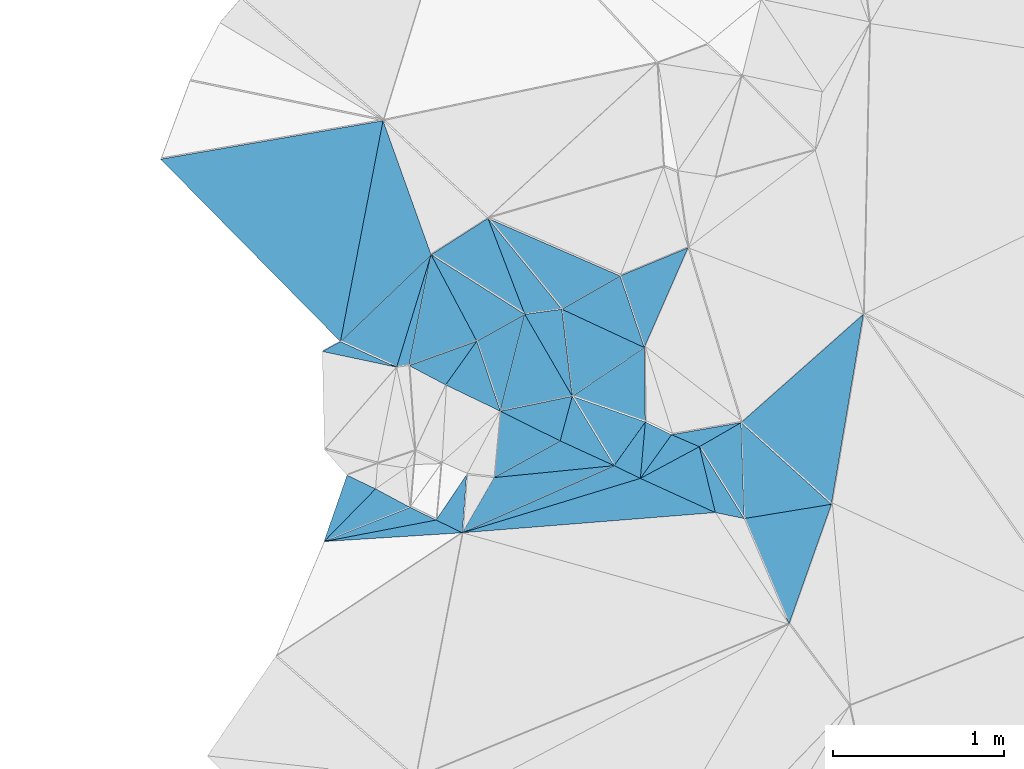
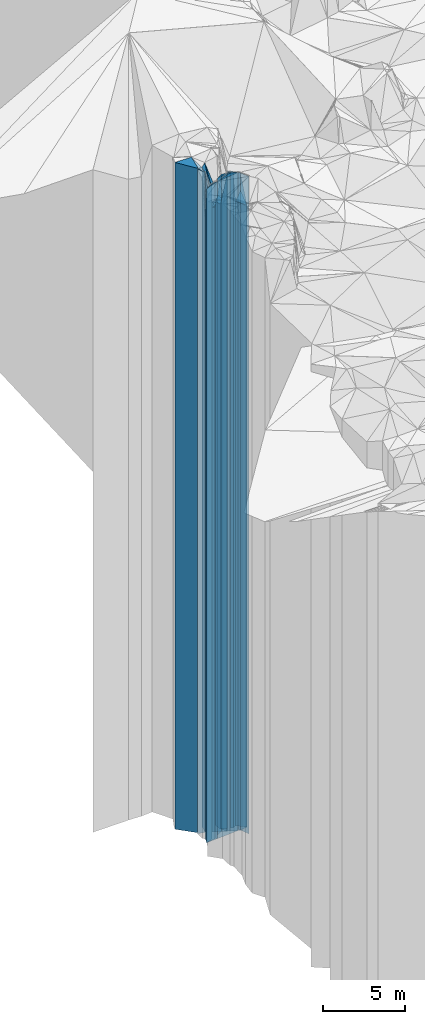
# One storey, part 237 of 275: 42 plates.
"""IFC2X3 building model written with IfcOpenShell, lengths in millimetres."""

from ifc_helpers import new_model, si_unit, frame, origin_with_axes, place, context, subcontext, project, spatial, faceted_brep, material, type_object, element, save


model = new_model("IFC2X3")

# Units and contexts
model_context = context("Model", 3, precision=1e-05, world=origin_with_axes())
body_context = subcontext(model_context, "Body", "Model", "MODEL_VIEW")
ifc_project = project(units=[si_unit("LENGTHUNIT", "METRE", prefix="MILLI"), si_unit("AREAUNIT", "SQUARE_METRE"), si_unit("VOLUMEUNIT", "CUBIC_METRE"), si_unit("MASSUNIT", "GRAM", prefix="KILO"), si_unit("TIMEUNIT", "SECOND"), si_unit("PLANEANGLEUNIT", "RADIAN"), si_unit("SOLIDANGLEUNIT", "STERADIAN"), si_unit("THERMODYNAMICTEMPERATUREUNIT", "DEGREE_CELSIUS"), si_unit("LUMINOUSINTENSITYUNIT", "LUMEN")], contexts=[model_context])

# Site, building, storey
site_placement = place(None, origin_with_axes())
site = spatial("IfcSite", under=ifc_project, at=site_placement, CompositionType="ELEMENT")
building_placement = place(site_placement, origin_with_axes())
building = spatial("IfcBuilding", under=site, at=building_placement, Name="Undefined", CompositionType="ELEMENT")
storey_placement = place(building_placement, origin_with_axes())
storey = spatial("IfcBuildingStorey", under=building, at=storey_placement, Name="Undefined", CompositionType="ELEMENT", Elevation=0.0)

# Plates
ifc_material = material()
plate_type_1 = type_object("IfcPlateType", PredefinedType="NOTDEFINED")
plate_1_placement = place(storey_placement, frame((-136041.558741659, 92091.3909936193, 32264.0), z_axis=(0.971640857863076, 0.236461504966677, 0.0), x_axis=(0.236461504966685, -0.971640857863074, 0.0)))
element("IfcPlate", 1, at=plate_1_placement, inside=storey, type_object=plate_type_1, material=ifc_material, Name="00", context=body_context, shape_type="Brep", body=[
    faceted_brep([(-2.91038304567337e-11, -24436.0, -1.45519152283669e-11), (469.926422119141, -24526.0, 155.464370727539), (469.926422119141, 24436.0, 155.464370727539), (0.0, 24436.0, 0.0), (396.232269287109, -24586.0, 2.66300048679113e-09), (396.232269287109, 24436.0, 2.66300048679113e-09)], [[[0, 1, 2, 3]], [[1, 4, 5, 2]], [[4, 0, 3, 5]], [[5, 3, 2]], [[4, 1, 0]]]),
])
plate_type_2 = type_object("IfcPlateType", PredefinedType="NOTDEFINED")
plate_2_placement = place(storey_placement, frame((-135779.383697276, 91671.5526365072, 31079.0), z_axis=(-0.999471889003235, -0.0324952780001071, 0.0), x_axis=(-0.0324952780001202, 0.999471889003235, 0.0)))
element("IfcPlate", 2, at=plate_2_placement, inside=storey, type_object=plate_type_2, material=ifc_material, Name="00", context=body_context, shape_type="Brep", body=[
    faceted_brep([(0.0, -25711.0, 2.91038304567337e-11), (428.136077880859, -25621.0, 248.393829345732), (428.136077880859, 23251.0, 248.393829345732), (0.0, 23251.0, 2.91038304567337e-11), (560.802978515625, -23251.0, -5.82076609134674e-10), (560.802978515625, 23251.0, -5.82076609134674e-10)], [[[0, 1, 2, 3]], [[1, 4, 5, 2]], [[4, 0, 3, 5]], [[5, 3, 2]], [[4, 1, 0]]]),
])
plate_type_3 = type_object("IfcPlateType", PredefinedType="NOTDEFINED")
plate_3_placement = place(storey_placement, frame((-135947.865066288, 91706.3955453406, 32264.0), z_axis=(-0.971640857863076, -0.236461504966677, 0.0), x_axis=(-0.236461504966676, 0.971640857863076, 0.0)))
element("IfcPlate", 3, at=plate_3_placement, inside=storey, type_object=plate_type_3, material=ifc_material, Name="00", context=body_context, shape_type="Brep", body=[
    faceted_brep([(1.45519152283669e-11, -24586.0, 1.45519152283669e-11), (297.805145263686, -24576.0, 378.565856933623), (297.805145263686, 24436.0, 378.565856933623), (0.0, 24436.0, 0.0), (396.232269287124, -24436.0, 2.6775524020195e-09), (396.232269287109, 24436.0, 2.66300048679113e-09)], [[[0, 1, 2, 3]], [[1, 4, 5, 2]], [[4, 0, 3, 5]], [[5, 3, 2]], [[4, 1, 0]]]),
])
plate_type_4 = type_object("IfcPlateType", PredefinedType="NOTDEFINED")
plate_4_placement = place(storey_placement, frame((-137609.148746292, 93213.2918704249, 32359.0), z_axis=(0.956207195936515, -0.292690618980567, 0.0), x_axis=(-0.292690618980582, -0.95620719593651, 0.0)))
element("IfcPlate", 4, at=plate_4_placement, inside=storey, type_object=plate_type_4, material=ifc_material, Name="00", context=body_context, shape_type="Brep", body=[
    faceted_brep([(0.0, -24531.0, -2.91038304567337e-11), (656.994262695305, -24601.0, 66.0193405151076), (656.994262695305, 24531.0, 66.0193405151076), (0.0, 24531.0, -2.91038304567337e-11), (687.67724609375, -24631.0, -2.03726813197136e-09), (687.67724609375, 24531.0, -2.03726813197136e-09)], [[[0, 1, 2, 3]], [[1, 4, 5, 2]], [[4, 0, 3, 5]], [[5, 3, 2]], [[4, 1, 0]]]),
])
plate_type_5 = type_object("IfcPlateType", PredefinedType="NOTDEFINED")
plate_5_placement = place(storey_placement, frame((-136357.056062541, 92236.1716570943, 31079.0), z_axis=(-0.999895629829874, -0.0144474719975415, 0.0), x_axis=(-0.0144474719975515, 0.999895629829874, 0.0)))
element("IfcPlate", 5, at=plate_5_placement, inside=storey, type_object=plate_type_5, material=ifc_material, Name="00", context=body_context, shape_type="Brep", body=[
    faceted_brep([(0.0, -25651.0, -2.91038304567337e-11), (156.226181030288, -23251.0, 424.962799072295), (156.226181030288, 23251.0, 424.962799072295), (0.0, 23251.0, 2.91038304567337e-11), (434.626281738296, -23271.0, -1.01863406598568e-09), (434.626281738296, 23251.0, -1.01863406598568e-09)], [[[0, 1, 2, 3]], [[1, 4, 5, 2]], [[4, 0, 3, 5]], [[5, 3, 2]], [[4, 1, 0]]]),
])
plate_type_6 = type_object("IfcPlateType", PredefinedType="NOTDEFINED")
plate_6_placement = place(storey_placement, frame((-136784.231584022, 92386.2418868125, 31079.0), z_axis=(-0.560021342031203, 0.82847818104617, 0.0), x_axis=(0.828478181046171, 0.560021342031202, 0.0)))
element("IfcPlate", 6, at=plate_6_placement, inside=storey, type_object=plate_type_6, material=ifc_material, Name="00", context=body_context, shape_type="Brep", body=[
    faceted_brep([(7.27595761418343e-12, -23251.0, 2.91038304567337e-11), (234.432464599631, -23301.0, 455.676879882842), (234.432464599631, 23251.0, 455.676879882842), (0.0, 23251.0, 2.91038304567337e-11), (508.035430908203, -23271.0, -1.54250301420689e-09), (508.035430908203, 23251.0, -1.54250301420689e-09)], [[[0, 1, 2, 3]], [[1, 4, 5, 2]], [[4, 0, 3, 5]], [[5, 3, 2]], [[4, 1, 0]]]),
])
plate_type_7 = type_object("IfcPlateType", PredefinedType="NOTDEFINED")
plate_7_placement = place(storey_placement, frame((-136203.880321449, 92161.7593439945, 31079.0), z_axis=(0.397745432997045, 0.917495814993176, 0.0), x_axis=(0.917495814993178, -0.397745432997043, 0.0)))
element("IfcPlate", 7, at=plate_7_placement, inside=storey, type_object=plate_type_7, material=ifc_material, Name="00", context=body_context, shape_type="Brep", body=[
    faceted_brep([(0.0, -25651.0, -2.91038304567337e-11), (344.792388915987, -23251.0, 226.093368530255), (344.792388915987, 23251.0, 226.093368530255), (0.0, 23251.0, 2.91038304567337e-11), (176.918060302705, -25621.0, 1.37879396788776e-09), (176.918060302705, 23251.0, 1.37879396788776e-09)], [[[0, 1, 2, 3]], [[1, 4, 5, 2]], [[4, 0, 3, 5]], [[5, 3, 2]], [[4, 1, 0]]]),
])
plate_type_8 = type_object("IfcPlateType", PredefinedType="NOTDEFINED")
plate_8_placement = place(storey_placement, frame((-135779.383697276, 91671.5526365072, 30984.0), z_axis=(-0.161243552034099, 0.986914645208706, 0.0), x_axis=(0.986914645208708, 0.161243552034091, 0.0)))
element("IfcPlate", 8, at=plate_8_placement, inside=storey, type_object=plate_type_8, material=ifc_material, Name="00", context=body_context, shape_type="Brep", body=[
    faceted_brep([(0.0, -25806.0, 1.45519152283669e-11), (72.3931198119972, -23346.0, 556.110839843765), (72.3931198119972, 23156.0, 556.110839843765), (-7.27595761418343e-12, 23156.0, 0.0), (516.623657226548, -23156.0, 1.00408215075731e-09), (516.623657226548, 23156.0, 1.00408215075731e-09)], [[[0, 1, 2, 3]], [[1, 4, 5, 2]], [[4, 0, 3, 5]], [[5, 3, 2]], [[4, 1, 0]]]),
])
plate_type_9 = type_object("IfcPlateType", PredefinedType="NOTDEFINED")
plate_9_placement = place(storey_placement, frame((-137609.148746292, 93213.2918704249, 31104.0), z_axis=(0.88403111089803, 0.467428063946096, 0.0), x_axis=(0.467428063946066, -0.884031110898046, 0.0)))
element("IfcPlate", 9, at=plate_9_placement, inside=storey, type_object=plate_type_9, material=ifc_material, Name="00", context=body_context, shape_type="Brep", body=[
    faceted_brep([(0.0, -25786.0, 0.0), (563.876403808594, -23296.0, 321.315063476577), (563.876403808594, 23276.0, 321.315063476577), (0.0, 23276.0, 0.0), (571.401794433594, -23276.0, 1.30967237055302e-10), (571.401794433594, 23276.0, 1.30967237055302e-10)], [[[0, 1, 2, 3]], [[1, 4, 5, 2]], [[4, 0, 3, 5]], [[5, 3, 2]], [[4, 1, 0]]]),
])
plate_type_10 = type_object("IfcPlateType", PredefinedType="NOTDEFINED")
plate_10_placement = place(storey_placement, frame((-136784.231584022, 92386.2418868125, 31079.0), z_axis=(-0.992897616102511, -0.118971946012288, 0.0), x_axis=(-0.118971946012274, 0.992897616102513, 0.0)))
element("IfcPlate", 10, at=plate_10_placement, inside=storey, type_object=plate_type_10, material=ifc_material, Name="00", context=body_context, shape_type="Brep", body=[
    faceted_brep([(7.27595761418343e-12, -23251.0, 2.91038304567337e-11), (508.347106933608, -23321.0, 218.364852905288), (508.347106933608, 23251.0, 218.364852905288), (0.0, 23251.0, 2.91038304567337e-11), (512.445129394531, -23301.0, 3.79804987460375e-09), (512.445129394531, 23251.0, 3.79804987460375e-09)], [[[0, 1, 2, 3]], [[1, 4, 5, 2]], [[4, 0, 3, 5]], [[5, 3, 2]], [[4, 1, 0]]]),
])
plate_type_11 = type_object("IfcPlateType", PredefinedType="NOTDEFINED")
plate_11_placement = place(storey_placement, frame((-136504.686318748, 93089.3453249089, 31089.0), z_axis=(0.947440181025233, 0.319932967008517, 0.0), x_axis=(0.319932967008536, -0.947440181025227, 0.0)))
element("IfcPlate", 11, at=plate_11_placement, inside=storey, type_object=plate_type_11, material=ifc_material, Name="00", context=body_context, shape_type="Brep", body=[
    faceted_brep([(0.0, -23411.0, 0.0), (-28.9714393616014, -23391.0, 429.139434814424), (-28.9714393616014, 23261.0, 429.139434814424), (0.0, 23261.0, 0.0), (441.814453125, -23261.0, 1.89174897968769e-09), (441.814453125, 23261.0, 1.89174897968769e-09)], [[[0, 1, 2, 3]], [[1, 4, 5, 2]], [[4, 0, 3, 5]], [[5, 3, 2]], [[4, 1, 0]]]),
])
plate_type_12 = type_object("IfcPlateType", PredefinedType="NOTDEFINED")
plate_12_placement = place(storey_placement, frame((-138139.112548315, 92705.6124749946, 32359.0), z_axis=(-0.691761460959168, 0.722126083957392, 0.0), x_axis=(0.722126083957394, 0.691761460959166, 0.0)))
element("IfcPlate", 12, at=plate_12_placement, inside=storey, type_object=plate_type_12, material=ifc_material, Name="00", context=body_context, shape_type="Brep", body=[
    faceted_brep([(-1.45519152283669e-11, -24941.0, 0.0), (1073.04370117188, -24921.0, 759.919311523438), (1073.04370117188, 24531.0, 759.919311523438), (0.0, 24531.0, -2.91038304567337e-11), (733.893737792969, -24531.0, -2.00816430151463e-09), (733.893737792969, 24531.0, -2.00816430151463e-09)], [[[0, 1, 2, 3]], [[1, 4, 5, 2]], [[4, 0, 3, 5]], [[5, 3, 2]], [[4, 1, 0]]]),
])
plate_type_13 = type_object("IfcPlateType", PredefinedType="NOTDEFINED")
plate_13_placement = place(storey_placement, frame((-136845.198177058, 92895.0474238634, 31104.0), z_axis=(-0.495599859991453, 0.868550964985045, 0.0), x_axis=(0.868550964985053, 0.495599859991438, 0.0)))
element("IfcPlate", 13, at=plate_13_placement, inside=storey, type_object=plate_type_13, material=ifc_material, Name="00", context=body_context, shape_type="Brep", body=[
    faceted_brep([(1.45519152283669e-11, -23276.0, 0.0), (-111.721611022935, -25906.0, 674.920959472656), (-111.721611022935, 23276.0, 674.920959472656), (0.0, 23276.0, 0.0), (392.045928955093, -23396.0, -2.3283064365387e-09), (392.045928955093, 23276.0, -2.3283064365387e-09)], [[[0, 1, 2, 3]], [[1, 4, 5, 2]], [[4, 0, 3, 5]], [[5, 3, 2]], [[4, 1, 0]]]),
])
plate_type_14 = type_object("IfcPlateType", PredefinedType="NOTDEFINED")
plate_14_placement = place(storey_placement, frame((-136504.686318748, 93089.3453249089, 31089.0), z_axis=(0.495599859991453, -0.868550964985045, 0.0), x_axis=(-0.868550964985035, -0.49559985999147, 0.0)))
element("IfcPlate", 14, at=plate_14_placement, inside=storey, type_object=plate_type_14, material=ifc_material, Name="00", context=body_context, shape_type="Brep", body=[
    faceted_brep([(0.0, -23411.0, 0.0), (84.6839599609229, -23261.0, 433.622680664063), (84.6839599609229, 23261.0, 433.622680664063), (0.0, 23261.0, 0.0), (392.045928955078, -23291.0, -2.3283064365387e-09), (392.045928955078, 23261.0, -2.3283064365387e-09)], [[[0, 1, 2, 3]], [[1, 4, 5, 2]], [[4, 0, 3, 5]], [[5, 3, 2]], [[4, 1, 0]]]),
])
plate_type_15 = type_object("IfcPlateType", PredefinedType="NOTDEFINED")
plate_15_placement = place(storey_placement, frame((-137061.524566055, 92864.9992388348, 31104.0), z_axis=(-0.137581187998973, 0.990490492992634, 0.0), x_axis=(0.990490492992633, 0.137581187998979, 0.0)))
element("IfcPlate", 15, at=plate_15_placement, inside=storey, type_object=plate_type_15, material=ifc_material, Name="00", context=body_context, shape_type="Brep", body=[
    faceted_brep([(0.0, -23296.0, 0.0), (-135.986953735366, -25906.0, 585.156005859375), (-135.986953735366, 23276.0, 585.156005859375), (0.0, 23276.0, 0.0), (218.403289794922, -23276.0, -9.16770659387112e-10), (218.403289794922, 23276.0, -9.16770659387112e-10)], [[[0, 1, 2, 3]], [[1, 4, 5, 2]], [[4, 0, 3, 5]], [[5, 3, 2]], [[4, 1, 0]]]),
])
plate_type_16 = type_object("IfcPlateType", PredefinedType="NOTDEFINED")
plate_16_placement = place(storey_placement, frame((-137738.316629679, 92565.7459972227, 31104.0), z_axis=(-0.338207177069304, 0.94107167919283, 0.0), x_axis=(0.941071679192833, 0.338207177069296, 0.0)))
element("IfcPlate", 16, at=plate_16_placement, inside=storey, type_object=plate_type_16, material=ifc_material, Name="00", context=body_context, shape_type="Brep", body=[
    faceted_brep([(0.0, -25856.0, 0.0), (340.560913085938, -25786.0, 565.701599121094), (340.560913085938, 23276.0, 565.701599121094), (0.0, 23276.0, 0.0), (421.070068359404, -23276.0, 2.88127921521664e-09), (421.070068359404, 23276.0, 2.88127921521664e-09)], [[[0, 1, 2, 3]], [[1, 4, 5, 2]], [[4, 0, 3, 5]], [[5, 3, 2]], [[4, 1, 0]]]),
])
plate_type_17 = type_object("IfcPlateType", PredefinedType="NOTDEFINED")
plate_17_placement = place(storey_placement, frame((-139189.996780718, 93771.6998682641, 32554.0), z_axis=(0.712166546939761, 0.702010547940625, 0.0), x_axis=(0.702010547940622, -0.712166546939764, 0.0)))
element("IfcPlate", 17, at=plate_17_placement, inside=storey, type_object=plate_type_17, material=ifc_material, Name="00", context=body_context, shape_type="Brep", body=[
    faceted_brep([(0.0, -24926.0, 7.27595761418343e-12), (752.456481933594, -24726.0, 1083.79394531251), (752.456481933594, 24726.0, 1083.79394531251), (2.91038304567337e-11, 24726.0, 0.0), (1496.96362304688, -24746.0, -3.71073838323355e-10), (1496.96362304688, 24726.0, -3.71073838323355e-10)], [[[0, 1, 2, 3]], [[1, 4, 5, 2]], [[4, 0, 3, 5]], [[5, 3, 2]], [[4, 1, 0]]]),
])
plate_type_18 = type_object("IfcPlateType", PredefinedType="NOTDEFINED")
plate_18_placement = place(storey_placement, frame((-137061.524566055, 92864.9992388348, 31074.0), z_axis=(0.969472134967555, -0.245201507991795, 0.0), x_axis=(-0.245201507991806, -0.969472134967553, 0.0)))
element("IfcPlate", 18, at=plate_18_placement, inside=storey, type_object=plate_type_18, material=ifc_material, Name="00", context=body_context, shape_type="Brep", body=[
    faceted_brep([(0.0, -23326.0, -7.27595761418343e-12), (396.149261474588, -23256.0, 386.219848632813), (396.149261474588, 23246.0, 386.219848632813), (1.09139364212751e-11, 23246.0, 2.91038304567337e-11), (584.12329101561, -23246.0, -5.82076609134674e-10), (584.12329101561, 23246.0, -5.82076609134674e-10)], [[[0, 1, 2, 3]], [[1, 4, 5, 2]], [[4, 0, 3, 5]], [[5, 3, 2]], [[4, 1, 0]]]),
])
plate_type_19 = type_object("IfcPlateType", PredefinedType="NOTDEFINED")
plate_19_placement = place(storey_placement, frame((-137061.524566055, 92864.9992388348, 31114.0), z_axis=(-0.933637365146917, -0.358219584056374, 0.0), x_axis=(-0.35821958405635, 0.933637365146927, 0.0)))
element("IfcPlate", 19, at=plate_19_placement, inside=storey, type_object=plate_type_19, material=ifc_material, Name="00", context=body_context, shape_type="Brep", body=[
    faceted_brep([(-1.09139364212751e-11, -23286.0, 0.0), (521.348693847685, -25776.0, 386.517150878906), (521.348693847685, 23286.0, 386.517150878906), (0.0, 23286.0, 0.0), (600.74951171875, -25896.0, 3.97267285734415e-09), (600.74951171875, 23286.0, 3.97267285734415e-09)], [[[0, 1, 2, 3]], [[1, 4, 5, 2]], [[4, 0, 3, 5]], [[5, 3, 2]], [[4, 1, 0]]]),
])
plate_type_20 = type_object("IfcPlateType", PredefinedType="NOTDEFINED")
plate_20_placement = place(storey_placement, frame((-136386.114562693, 91906.2389312714, 32279.0), z_axis=(-0.81415573206253, 0.580646574044595, 0.0), x_axis=(0.580646574044601, 0.814155732062526, 0.0)))
element("IfcPlate", 20, at=plate_20_placement, inside=storey, type_object=plate_type_20, material=ifc_material, Name="00", context=body_context, shape_type="Brep", body=[
    faceted_brep([(0.0, -24561.0, 0.0), (285.489349365218, -24451.0, 167.916168212891), (285.489349365218, 24451.0, 167.916168212891), (-1.63709046319127e-11, 24451.0, 0.0), (313.847106933577, -24451.0, 2.44472175836563e-09), (313.847106933577, 24451.0, 2.44472175836563e-09)], [[[0, 1, 2, 3]], [[1, 4, 5, 2]], [[4, 0, 3, 5]], [[5, 3, 2]], [[4, 1, 0]]]),
])
plate_21_placement = place(storey_placement, frame((-136357.056062541, 92236.1716570943, 32279.0), z_axis=(0.814155732062535, -0.580646574044588, 0.0), x_axis=(-0.580646574044615, -0.814155732062516, 0.0)))
element("IfcPlate", 21, at=plate_21_placement, inside=storey, type_object=plate_type_20, material=ifc_material, Name="00", context=body_context, shape_type="Brep", body=[
    faceted_brep([(7.27595761418343e-12, -24451.0, -2.91038304567337e-11), (285.489349365237, -24561.0, 167.916168212891), (285.489349365218, 24451.0, 167.916168212891), (-1.63709046319127e-11, 24451.0, 0.0), (313.847106933582, -24551.0, 2.4156179279089e-09), (313.847106933577, 24451.0, 2.44472175836563e-09)], [[[0, 1, 2, 3]], [[1, 4, 5, 2]], [[4, 0, 3, 5]], [[5, 3, 2]], [[4, 1, 0]]]),
])
plate_type_21 = type_object("IfcPlateType", PredefinedType="NOTDEFINED")
plate_22_placement = place(storey_placement, frame((-137204.752473843, 92298.7080006626, 31074.0), z_axis=(0.443714606160807, 0.896168147324797, 0.0), x_axis=(0.896168147521672, -0.443714605763182, 0.0)))
element("IfcPlate", 22, at=plate_22_placement, inside=storey, type_object=plate_type_21, material=ifc_material, Name="00", context=body_context, shape_type="Brep", body=[
    faceted_brep([(1.09139364212751e-11, -23246.0, 2.91038304567337e-11), (338.017364384315, -23256.0, 265.036346435547), (338.017364384315, 23246.0, 265.036346435547), (1.09139364212751e-11, 23246.0, 2.91038304567337e-11), (390.512481689395, -25716.0, 1.07684172689915e-09), (390.512481689395, 23246.0, 1.07684172689915e-09)], [[[0, 1, 2, 3]], [[1, 4, 5, 2]], [[4, 0, 3, 5]], [[5, 3, 2]], [[4, 1, 0]]]),
])
plate_type_22 = type_object("IfcPlateType", PredefinedType="NOTDEFINED")
plate_23_placement = place(storey_placement, frame((-136386.114562693, 91906.2389312714, 32264.0), z_axis=(-0.473350498214962, 0.880874171400006, 0.0), x_axis=(0.880874171400003, 0.473350498214967, 0.0)))
element("IfcPlate", 23, at=plate_23_placement, inside=storey, type_object=plate_type_22, material=ifc_material, Name="00", context=body_context, shape_type="Brep", body=[
    faceted_brep([(2.91038304567337e-11, -24576.0, 1.45519152283669e-11), (281.47616577147, -24466.0, 138.820663452178), (281.47616577147, 24436.0, 138.820663452178), (0.0, 24436.0, 0.0), (391.152130126953, -24436.0, 3.75439412891865e-09), (391.152130126953, 24436.0, 3.75439412891865e-09)], [[[0, 1, 2, 3]], [[1, 4, 5, 2]], [[4, 0, 3, 5]], [[5, 3, 2]], [[4, 1, 0]]]),
])
plate_type_23 = type_object("IfcPlateType", PredefinedType="NOTDEFINED")
plate_24_placement = place(storey_placement, frame((-136539.290303785, 91980.6512443711, 31079.0), z_axis=(-0.81415573206253, 0.580646574044595, 0.0), x_axis=(0.580646574044601, 0.814155732062526, 0.0)))
element("IfcPlate", 24, at=plate_24_placement, inside=storey, type_object=plate_type_23, material=ifc_material, Name="00", context=body_context, shape_type="Brep", body=[
    faceted_brep([(-1.72803993336856e-11, -25751.0, 0.0), (187.989624023406, -23251.0, 434.925170898438), (187.989624023406, 23251.0, 434.925170898438), (0.0, 23251.0, 2.91038304567337e-11), (313.847106933562, -25651.0, 2.38651409745216e-09), (313.847106933562, 23251.0, 2.38651409745216e-09)], [[[0, 1, 2, 3]], [[1, 4, 5, 2]], [[4, 0, 3, 5]], [[5, 3, 2]], [[4, 1, 0]]]),
])
plate_type_24 = type_object("IfcPlateType", PredefinedType="NOTDEFINED")
plate_25_placement = place(storey_placement, frame((-135779.383697276, 91671.5526365072, 30984.0), z_axis=(0.920517110220634, 0.390702252093654, 0.0), x_axis=(0.390702252093661, -0.920517110220631, 0.0)))
element("IfcPlate", 25, at=plate_25_placement, inside=storey, type_object=plate_type_24, material=ifc_material, Name="00", context=body_context, shape_type="Brep", body=[
    faceted_brep([(0.0, -25806.0, 1.45519152283669e-11), (122.523666381836, -23156.0, 501.884399414048), (122.523666381836, 23156.0, 501.884399414048), (-7.27595761418343e-12, 23156.0, 0.0), (670.074645996094, -25826.0, 5.79166226089001e-09), (670.074645996094, 23156.0, 5.79166226089001e-09)], [[[0, 1, 2, 3]], [[1, 4, 5, 2]], [[4, 0, 3, 5]], [[5, 3, 2]], [[4, 1, 0]]]),
])
plate_type_25 = type_object("IfcPlateType", PredefinedType="NOTDEFINED")
plate_26_placement = place(storey_placement, frame((-135797.607146299, 92232.0594659979, 30984.0), z_axis=(0.670458691751183, 0.741946859724665, 0.0), x_axis=(0.741946859724667, -0.670458691751181, 0.0)))
element("IfcPlate", 26, at=plate_26_placement, inside=storey, type_object=plate_type_25, material=ifc_material, Name="00", context=body_context, shape_type="Brep", body=[
    faceted_brep([(0.0, -23346.0, -1.09139364212751e-11), (105.93482208249, -23546.0, 949.198486328114), (105.93482208249, 23156.0, 949.198486328114), (-7.27595761418343e-12, 23156.0, 0.0), (711.758361816377, -23156.0, 4.77666617371142e-09), (711.758361816377, 23156.0, 4.77666617371142e-09)], [[[0, 1, 2, 3]], [[1, 4, 5, 2]], [[4, 0, 3, 5]], [[5, 3, 2]], [[4, 1, 0]]]),
])
plate_type_26 = type_object("IfcPlateType", PredefinedType="NOTDEFINED")
plate_27_placement = place(storey_placement, frame((-136784.231584022, 92386.2418868125, 31079.0), z_axis=(0.965301039998365, -0.261139621999563, 0.0), x_axis=(-0.261139621999507, -0.96530103999838, 0.0)))
element("IfcPlate", 27, at=plate_27_placement, inside=storey, type_object=plate_type_26, material=ifc_material, Name="00", context=body_context, shape_type="Brep", body=[
    faceted_brep([(7.27595761418343e-12, -23251.0, 2.91038304567337e-11), (327.553192138657, -25751.0, 342.357849121065), (327.553192138657, 23251.0, 342.357849121065), (0.0, 23251.0, 2.91038304567337e-11), (270.185119628914, -25711.0, 2.27009877562523e-09), (270.185119628914, 23251.0, 2.27009877562523e-09)], [[[0, 1, 2, 3]], [[1, 4, 5, 2]], [[4, 0, 3, 5]], [[5, 3, 2]], [[4, 1, 0]]]),
])
plate_type_27 = type_object("IfcPlateType", PredefinedType="NOTDEFINED")
plate_28_placement = place(storey_placement, frame((-135947.865066288, 91706.3955453406, 32294.0), z_axis=(-0.414902247044917, -0.909865993098478, 0.0), x_axis=(-0.909865993098479, 0.414902247044913, 0.0)))
element("IfcPlate", 28, at=plate_28_placement, inside=storey, type_object=plate_type_27, material=ifc_material, Name="00", context=body_context, shape_type="Brep", body=[
    faceted_brep([(0.0, -24556.0, -7.27595761418343e-12), (1296.33996582034, -24466.0, 720.834777832031), (1296.33996582034, 24466.0, 720.834777832031), (0.0, 24466.0, -7.27595761418343e-12), (481.663787841768, -24546.0, 7.6397554948926e-10), (481.663787841768, 24466.0, 7.6397554948926e-10)], [[[0, 1, 2, 3]], [[1, 4, 5, 2]], [[4, 0, 3, 5]], [[5, 3, 2]], [[4, 1, 0]]]),
])
plate_type_28 = type_object("IfcPlateType", PredefinedType="NOTDEFINED")
plate_29_placement = place(storey_placement, frame((-137061.524566055, 92864.9992388348, 31074.0), z_axis=(0.487998675933438, -0.872844368880966, 0.0), x_axis=(-0.872844368880958, -0.487998675933451, 0.0)))
element("IfcPlate", 29, at=plate_29_placement, inside=storey, type_object=plate_type_28, material=ifc_material, Name="00", context=body_context, shape_type="Brep", body=[
    faceted_brep([(0.0, -23326.0, -7.27595761418343e-12), (401.365051269517, -23246.0, 424.389099121094), (401.365051269517, 23246.0, 424.389099121094), (1.09139364212751e-11, 23246.0, 2.91038304567337e-11), (321.403167724595, -23306.0, 1.28056854009628e-09), (321.403167724595, 23246.0, 1.28056854009628e-09)], [[[0, 1, 2, 3]], [[1, 4, 5, 2]], [[4, 0, 3, 5]], [[5, 3, 2]], [[4, 1, 0]]]),
])
plate_type_29 = type_object("IfcPlateType", PredefinedType="NOTDEFINED")
plate_30_placement = place(storey_placement, frame((-136386.114562693, 91906.2389312714, 32294.0), z_axis=(-0.436964148096435, -0.899478923198513, 0.0), x_axis=(-0.899478923198528, 0.436964148096405, 0.0)))
element("IfcPlate", 30, at=plate_30_placement, inside=storey, type_object=plate_type_29, material=ifc_material, Name="00", context=body_context, shape_type="Brep", body=[
    faceted_brep([(0.0, -24546.0, 0.0), (796.857849121181, -24466.0, 740.48468017581), (796.857849121181, 24466.0, 740.48468017581), (0.0, 24466.0, -7.27595761418343e-12), (170.293869018584, -24536.0, 1.30967237055302e-09), (170.293869018584, 24466.0, 1.30967237055302e-09)], [[[0, 1, 2, 3]], [[1, 4, 5, 2]], [[4, 0, 3, 5]], [[5, 3, 2]], [[4, 1, 0]]]),
])
plate_type_30 = type_object("IfcPlateType", PredefinedType="NOTDEFINED")
plate_31_placement = place(storey_placement, frame((-137342.059516205, 92708.1549155583, 31074.0), z_axis=(0.814155732062535, -0.580646574044588, 0.0), x_axis=(-0.580646574044615, -0.814155732062516, 0.0)))
element("IfcPlate", 31, at=plate_31_placement, inside=storey, type_object=plate_type_30, material=ifc_material, Name="00", context=body_context, shape_type="Brep", body=[
    faceted_brep([(-2.91038304567337e-11, -23306.0, -1.45519152283669e-11), (253.626693725606, -23246.0, 349.533264160127), (253.626693725606, 23246.0, 349.533264160127), (1.09139364212751e-11, 23246.0, 2.91038304567337e-11), (313.847106933599, -23246.0, 2.38651409745216e-09), (313.847106933599, 23246.0, 2.38651409745216e-09)], [[[0, 1, 2, 3]], [[1, 4, 5, 2]], [[4, 0, 3, 5]], [[5, 3, 2]], [[4, 1, 0]]]),
])
plate_type_31 = type_object("IfcPlateType", PredefinedType="NOTDEFINED")
plate_32_placement = place(storey_placement, frame((-137241.028676465, 91910.9141931781, 32289.0), z_axis=(0.866958842448887, -0.498379740258055, 0.0), x_axis=(-0.498379740258035, -0.866958842448898, 0.0)))
element("IfcPlate", 32, at=plate_32_placement, inside=storey, type_object=plate_type_31, material=ifc_material, Name="00", context=body_context, shape_type="Brep", body=[
    faceted_brep([(-1.45519152283669e-11, -24461.0, 0.0), (-410.191345214844, -24541.0, 573.62274169919), (-410.191345214844, 24461.0, 573.62274169919), (1.45519152283669e-11, 24461.0, 4.36557456851006e-11), (372.021514892593, -24471.0, 1.16415321826935e-10), (372.021514892593, 24461.0, 1.16415321826935e-10)], [[[0, 1, 2, 3]], [[1, 4, 5, 2]], [[4, 0, 3, 5]], [[5, 3, 2]], [[4, 1, 0]]]),
])
plate_type_32 = type_object("IfcPlateType", PredefinedType="NOTDEFINED")
plate_33_placement = place(storey_placement, frame((-137738.316629679, 92565.7459972227, 31074.0), z_axis=(0.467259276108219, 0.884120336204763, 0.0), x_axis=(0.884120336204771, -0.467259276108203, 0.0)))
element("IfcPlate", 33, at=plate_33_placement, inside=storey, type_object=plate_type_32, material=ifc_material, Name="00", context=body_context, shape_type="Brep", body=[
    faceted_brep([(2.91038304567337e-11, -25886.0, 2.18278728425503e-11), (283.797088623047, -23306.0, 311.061431884787), (283.797088623047, 23246.0, 311.061431884787), (1.09139364212751e-11, 23246.0, 2.91038304567337e-11), (242.074371337891, -23246.0, 1.89174897968769e-10), (242.074371337891, 23246.0, 1.89174897968769e-10)], [[[0, 1, 2, 3]], [[1, 4, 5, 2]], [[4, 0, 3, 5]], [[5, 3, 2]], [[4, 1, 0]]]),
])
plate_type_33 = type_object("IfcPlateType", PredefinedType="NOTDEFINED")
plate_34_placement = place(storey_placement, frame((-136539.290303785, 91980.6512443711, 32289.0), z_axis=(-0.417077766117323, -0.908870803255657, 0.0), x_axis=(-0.90887080325566, 0.417077766117317, 0.0)))
element("IfcPlate", 34, at=plate_34_placement, inside=storey, type_object=plate_type_33, material=ifc_material, Name="00", context=body_context, shape_type="Brep", body=[
    faceted_brep([(0.0, -24541.0, -3.63797880709171e-12), (608.703735351563, -24461.0, 356.061431884762), (608.703735351563, 24461.0, 356.061431884762), (1.45519152283669e-11, 24461.0, 4.36557456851006e-11), (347.131103515625, -24501.0, 2.2373569663614e-09), (347.131103515625, 24461.0, 2.2373569663614e-09)], [[[0, 1, 2, 3]], [[1, 4, 5, 2]], [[4, 0, 3, 5]], [[5, 3, 2]], [[4, 1, 0]]]),
])
plate_type_34 = type_object("IfcPlateType", PredefinedType="NOTDEFINED")
plate_35_placement = place(storey_placement, frame((-137609.148746292, 93213.2918704249, 32359.0), z_axis=(0.691761460959168, -0.722126083957392, 0.0), x_axis=(-0.722126083957374, -0.691761460959186, 0.0)))
element("IfcPlate", 35, at=plate_35_placement, inside=storey, type_object=plate_type_34, material=ifc_material, Name="00", context=body_context, shape_type="Brep", body=[
    faceted_brep([(0.0, -24531.0, -2.91038304567337e-11), (600.22314453125, -24631.0, 335.607177734317), (600.22314453125, 24531.0, 335.607177734317), (0.0, 24531.0, -2.91038304567337e-11), (733.893737792961, -24941.0, -2.00816430151463e-09), (733.893737792969, 24531.0, -2.00816430151463e-09)], [[[0, 1, 2, 3]], [[1, 4, 5, 2]], [[4, 0, 3, 5]], [[5, 3, 2]], [[4, 1, 0]]]),
])
plate_type_35 = type_object("IfcPlateType", PredefinedType="NOTDEFINED")
plate_36_placement = place(storey_placement, frame((-137810.425426011, 92555.7299355465, 32409.0), z_axis=(-0.414902247044917, -0.909865993098478, 0.0), x_axis=(-0.909865993098479, 0.414902247044913, 0.0)))
element("IfcPlate", 36, at=plate_36_placement, inside=storey, type_object=plate_type_35, material=ifc_material, Name="00", context=body_context, shape_type="Brep", body=[
    faceted_brep([(0.0, -24581.0, 7.27595761418343e-12), (433.497406005859, -24921.0, 96.3327560424805), (433.497406005859, 24581.0, 96.3327560424805), (0.0, 24581.0, 7.27595761418343e-12), (361.247833251953, -24891.0, 5.74800651520491e-10), (361.247833251953, 24581.0, 5.74800651520491e-10)], [[[0, 1, 2, 3]], [[1, 4, 5, 2]], [[4, 0, 3, 5]], [[5, 3, 2]], [[4, 1, 0]]]),
])
plate_type_36 = type_object("IfcPlateType", PredefinedType="NOTDEFINED")
plate_37_placement = place(storey_placement, frame((-137241.028676465, 91910.9141931781, 31074.0), z_axis=(-0.485538033276581, 0.874215544497986, 0.0), x_axis=(0.874215544497983, 0.485538033276586, 0.0)))
element("IfcPlate", 37, at=plate_37_placement, inside=storey, type_object=plate_type_36, material=ifc_material, Name="00", context=body_context, shape_type="Brep", body=[
    faceted_brep([(-2.91038304567337e-11, -25676.0, 0.0), (220.001861572237, -23246.0, 321.401885986299), (220.001861572237, 23246.0, 321.401885986299), (1.09139364212751e-11, 23246.0, 2.91038304567337e-11), (441.814453124985, -25716.0, 3.72529029846191e-09), (441.814453124985, 23246.0, 3.72529029846191e-09)], [[[0, 1, 2, 3]], [[1, 4, 5, 2]], [[4, 0, 3, 5]], [[5, 3, 2]], [[4, 1, 0]]]),
])
plate_type_37 = type_object("IfcPlateType", PredefinedType="NOTDEFINED")
plate_38_placement = place(storey_placement, frame((-137732.788139639, 91737.2114862952, 31029.0), z_axis=(-0.473653510187363, -0.880711276348378, 0.0), x_axis=(-0.880711276348378, 0.473653510187363, 0.0)))
element("IfcPlate", 38, at=plate_38_placement, inside=storey, type_object=plate_type_37, material=ifc_material, Name="00", context=body_context, shape_type="Brep", body=[
    faceted_brep([(0.0, -25591.0, 3.63797880709171e-12), (347.314971923857, -25501.0, 413.971374511737), (347.314971923857, 23201.0, 413.971374511737), (2.91038304567337e-11, 23201.0, 1.2732925824821e-11), (228.035079956055, -23201.0, 1.19689502753317e-09), (228.035079956084, 23201.0, 1.19871401693672e-09)], [[[0, 1, 2, 3]], [[1, 4, 5, 2]], [[4, 0, 3, 5]], [[5, 3, 2]], [[4, 1, 0]]]),
])
plate_type_38 = type_object("IfcPlateType", PredefinedType="NOTDEFINED")
plate_39_placement = place(storey_placement, frame((-137933.621210447, 91845.2211047096, 31024.0), z_axis=(-0.431226235827228, -0.902243832638539, 0.0), x_axis=(-0.902243832638532, 0.431226235827243, 0.0)))
element("IfcPlate", 39, at=plate_39_placement, inside=storey, type_object=plate_type_38, material=ifc_material, Name="00", context=body_context, shape_type="Brep", body=[
    faceted_brep([(0.0, -23206.0, 1.45519152283669e-11), (138.835494995117, -25506.0, 407.829254150405), (138.835494995117, 23196.0, 407.829254150405), (0.0, 23196.0, 1.45519152283669e-11), (184.390884399414, -23196.0, -1.49884726852179e-09), (184.390884399414, 23196.0, -1.49884726852179e-09)], [[[0, 1, 2, 3]], [[1, 4, 5, 2]], [[4, 0, 3, 5]], [[5, 3, 2]], [[4, 1, 0]]]),
])
plate_type_39 = type_object("IfcPlateType", PredefinedType="NOTDEFINED")
plate_40_placement = place(storey_placement, frame((-137401.422120028, 91927.4654246163, 32174.0), z_axis=(0.829515828344418, -0.558483205231879, 0.0), x_axis=(-0.558483205231914, -0.829515828344395, 0.0)))
element("IfcPlate", 40, at=plate_40_placement, inside=storey, type_object=plate_type_39, material=ifc_material, Name="00", context=body_context, shape_type="Brep", body=[
    faceted_brep([(1.45519152283669e-11, -24346.0, -2.91038304567337e-11), (295.241241455082, -24586.0, 168.619735717744), (295.241241455082, 24346.0, 168.619735717744), (2.91038304567337e-11, 24346.0, 1.45519152283669e-11), (319.061126708989, -24566.0, 2.18278728425503e-09), (319.061126708989, 24346.0, 2.18278728425503e-09)], [[[0, 1, 2, 3]], [[1, 4, 5, 2]], [[4, 0, 3, 5]], [[5, 3, 2]], [[4, 1, 0]]]),
])
plate_type_40 = type_object("IfcPlateType", PredefinedType="NOTDEFINED")
plate_41_placement = place(storey_placement, frame((-137426.436657455, 91588.3868600957, 32179.0), z_axis=(-0.436964148096435, -0.899478923198513, 0.0), x_axis=(-0.899478923198528, 0.436964148096405, 0.0)))
element("IfcPlate", 41, at=plate_41_placement, inside=storey, type_object=plate_type_40, material=ifc_material, Name="00", context=body_context, shape_type="Brep", body=[
    faceted_brep([(0.0, -24581.0, 7.27595761418343e-12), (704.664245605469, -24351.0, 399.309753417983), (704.664245605469, 24351.0, 399.309753417983), (0.0, 24351.0, 0.0), (170.293869018555, -24561.0, 1.32422428578138e-09), (170.293869018555, 24351.0, 1.32422428578138e-09)], [[[0, 1, 2, 3]], [[1, 4, 5, 2]], [[4, 0, 3, 5]], [[5, 3, 2]], [[4, 1, 0]]]),
])
plate_type_41 = type_object("IfcPlateType", PredefinedType="NOTDEFINED")
plate_42_placement = place(storey_placement, frame((-137579.612398547, 91662.7991731955, 32179.0), z_axis=(-0.436964148096435, -0.899478923198513, 0.0), x_axis=(-0.899478923198528, 0.436964148096405, 0.0)))
element("IfcPlate", 42, at=plate_42_placement, inside=storey, type_object=plate_type_41, material=ifc_material, Name="00", context=body_context, shape_type="Brep", body=[
    faceted_brep([(0.0, -24561.0, 0.0), (534.37042236331, -24351.0, 399.309753417987), (534.37042236331, 24351.0, 399.309753417987), (0.0, 24351.0, 0.0), (170.293869018584, -24441.0, 1.27693056128919e-09), (170.293869018555, 24351.0, 1.32422428578138e-09)], [[[0, 1, 2, 3]], [[1, 4, 5, 2]], [[4, 0, 3, 5]], [[5, 3, 2]], [[4, 1, 0]]]),
])

save(model, "model.ifc")
